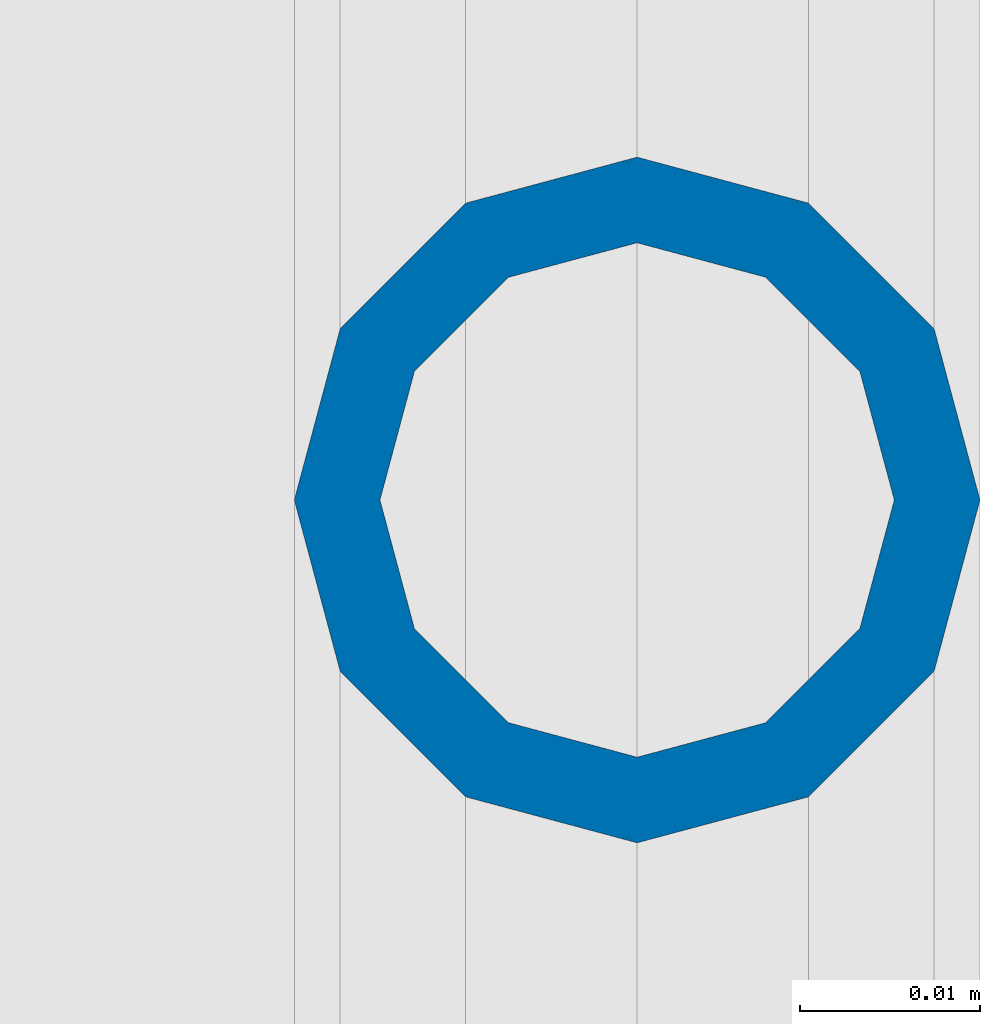
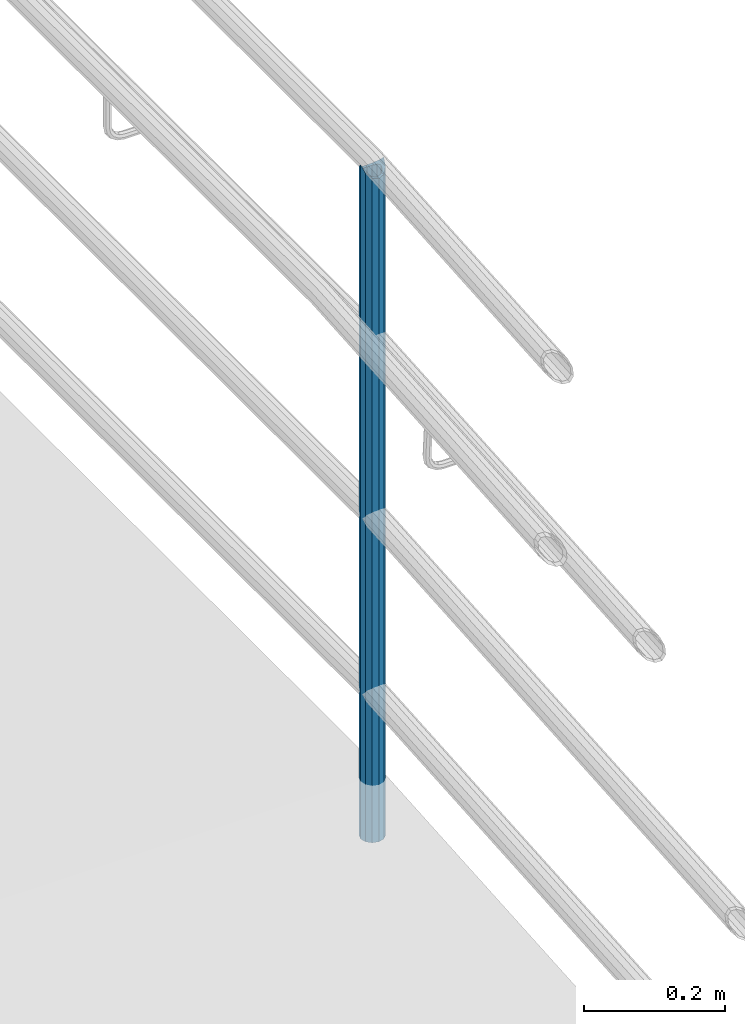
# One storey, part 661 of 1876: 1 column, 1 element without a shape of its own.
"""IFC2X3 building model written with IfcOpenShell, lengths in millimetres."""

from ifc_helpers import new_model, si_unit, frame, origin_with_axes, place, context, subcontext, project, spatial, faceted_brep, material, type_object, element, aggregate, save


model = new_model("IFC2X3")

# Units and contexts
model_context = context("Model", 3, precision=1e-05, world=origin_with_axes())
body_context = subcontext(model_context, "Body", "Model", "MODEL_VIEW")
ifc_project = project(units=[si_unit("LENGTHUNIT", "METRE", prefix="MILLI"), si_unit("AREAUNIT", "SQUARE_METRE"), si_unit("VOLUMEUNIT", "CUBIC_METRE"), si_unit("MASSUNIT", "GRAM", prefix="KILO"), si_unit("TIMEUNIT", "SECOND"), si_unit("PLANEANGLEUNIT", "RADIAN"), si_unit("SOLIDANGLEUNIT", "STERADIAN"), si_unit("THERMODYNAMICTEMPERATUREUNIT", "DEGREE_CELSIUS"), si_unit("LUMINOUSINTENSITYUNIT", "LUMEN")], contexts=[model_context])

# Site, building, storey
site_placement = place(None, origin_with_axes())
site = spatial("IfcSite", under=ifc_project, at=site_placement, CompositionType="ELEMENT")
building_placement = place(site_placement, origin_with_axes())
building = spatial("IfcBuilding", under=site, at=building_placement, Name="Undefined", CompositionType="ELEMENT")
storey_placement = place(building_placement, origin_with_axes())
storey = spatial("IfcBuildingStorey", under=building, at=storey_placement, Name="Undefined", CompositionType="ELEMENT", Elevation=0.0)

# Assembly, column
assembly_placement = place(storey_placement, origin_with_axes())
assembly = element("IfcElementAssembly", 1, at=assembly_placement, inside=storey, Name="RAIL", AssemblyPlace="NOTDEFINED", PredefinedType="RIGID_FRAME")
ifc_material = material()
column_type = type_object("IfcColumnType", PredefinedType="NOTDEFINED")
column_placement = place(assembly_placement, frame((9556.7501953125, -5181.60009765727, 76.2000030526367), z_axis=(0.0, 1.0, 0.0), x_axis=(0.0, 0.0, 1.0)))
column = element("IfcColumn", 2, at=column_placement, type_object=column_type, material=ifc_material, Name="POST", context=body_context, shape_type="Brep", body=[
    faceted_brep([(1151.90221606134, -9.52499999999964, 16.4977839420935), (1151.90221606134, -9.52499999999964, 9.99208795657023), (1151.26416204686, -7.14374999999927, 12.3733379565701), (1149.35000000343, 0.0, 14.2874999999999), (1149.35000000343, 0.0, 19.0500000000002), (1151.26416204686, 7.14374999999927, 12.3733379565701), (1151.90221606134, 9.52499999999964, 9.99208795657023), (1151.90221606134, 9.52499999999964, 16.4977839420935), (1168.40000000408, 19.0499999999993, 0.0), (1158.87500000343, 16.4977839420935, 9.52500000000009), (1158.87500000408, 16.4977839420935, -9.52500000000009), (1154.75055401791, 12.373337956571, 7.14375000000018), (1156.66471606134, 14.2875000000004, 0.0), (1154.75055401791, 12.373337956571, -7.14375000000018), (1151.90221606134, 9.52499999999964, -9.99208795657023), (1151.90221606199, 9.52499999999964, -16.4977839420935), (1151.26416204686, 7.14374999999927, -12.3733379565701), (1149.35000000343, 0.0, -14.2874999999999), (1149.35000000408, 0.0, -19.0500000000002), (1151.90221606134, -9.52499999999964, -9.99208795657023), (1151.90221606199, -9.52499999999964, -16.4977839420935), (1151.26416204686, -7.14374999999927, -12.3733379565701), (1168.40000000408, -19.0499999999993, 0.0), (1158.87500000408, -16.4977839420935, -9.52500000000009), (1158.87500000343, -16.4977839420935, 9.52500000000009), (1154.75055401791, -12.373337956571, -7.14375000000018), (1156.66471606134, -14.2875000000004, 0.0), (1154.75055401791, -12.373337956571, 7.14375000000018), (0.0, -16.4977839420935, -9.52500000000146), (0.0, -9.52500000000009, -16.4977839420935), (0.0, 0.0, -19.05), (0.0, 9.52500000000009, -16.4977839420935), (0.0, 16.4977839420935, -9.52500000000146), (-9.09494701772928e-13, 19.05, -1.81898940354586e-12), (0.0, 16.4977839420935, 9.52500000000146), (0.0, 9.52500000000009, 16.4977839420935), (0.0, 0.0, 19.0499999999993), (0.0, -9.52500000000009, 16.4977839420935), (0.0, -16.4977839420935, 9.52500000000146), (0.0, -19.0500000000002, 0.0), (0.0, -12.373337956571, -7.14375000000018), (0.0, -7.14374999999927, -12.3733379565701), (0.0, 0.0, -14.2874999999999), (0.0, 7.14374999999927, -12.3733379565701), (0.0, 12.373337956571, -7.14375000000018), (0.0, 14.2875000000004, 0.0), (0.0, 12.373337956571, 7.14375000000018), (0.0, 7.14374999999927, 12.3733379565701), (0.0, 0.0, 14.2874999999999), (0.0, -7.14374999999927, 12.3733379565701), (0.0, -12.373337956571, 7.14375000000018), (0.0, -14.2875000000004, 0.0)], [[[0, 1, 2, 3, 4]], [[4, 3, 5, 6, 7]], [[8, 9, 10]], [[7, 6, 11, 12, 13, 14, 15, 10, 9]], [[16, 17, 18, 15, 14]], [[19, 20, 18, 17, 21]], [[22, 23, 24]], [[24, 23, 20, 19, 25, 26, 27, 1, 0]], [[28, 29, 20, 23]], [[29, 30, 18, 20]], [[30, 31, 15, 18]], [[31, 32, 10, 15]], [[32, 33, 8, 10]], [[33, 34, 9, 8]], [[34, 35, 7, 9]], [[35, 36, 4, 7]], [[36, 37, 0, 4]], [[37, 38, 24, 0]], [[38, 39, 22, 24]], [[39, 28, 23, 22]], [[38, 37, 36, 35, 34, 33, 32, 31, 30, 29, 28, 39], [40, 41, 42, 43, 44, 45, 46, 47, 48, 49, 50, 51]], [[40, 51, 26, 25]], [[21, 41, 40, 25, 19]], [[42, 41, 21, 17]], [[43, 42, 17, 16]], [[44, 43, 16, 14, 13]], [[45, 44, 13, 12]], [[46, 45, 12, 11]], [[5, 47, 46, 11, 6]], [[48, 47, 5, 3]], [[49, 48, 3, 2]], [[50, 49, 2, 1, 27]], [[51, 50, 27, 26]]]),
])
aggregate(assembly, [column])

save(model, "model.ifc")
